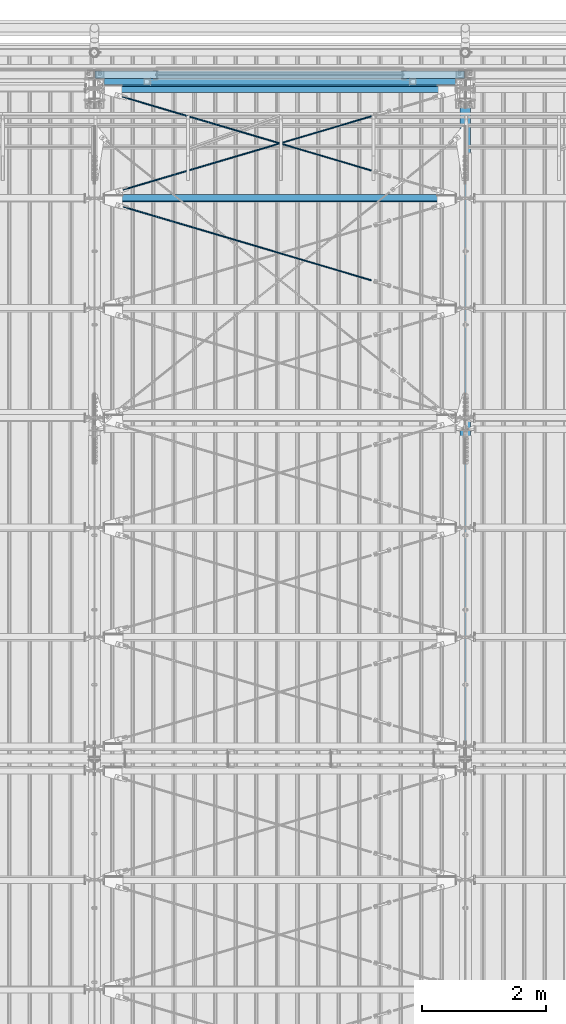
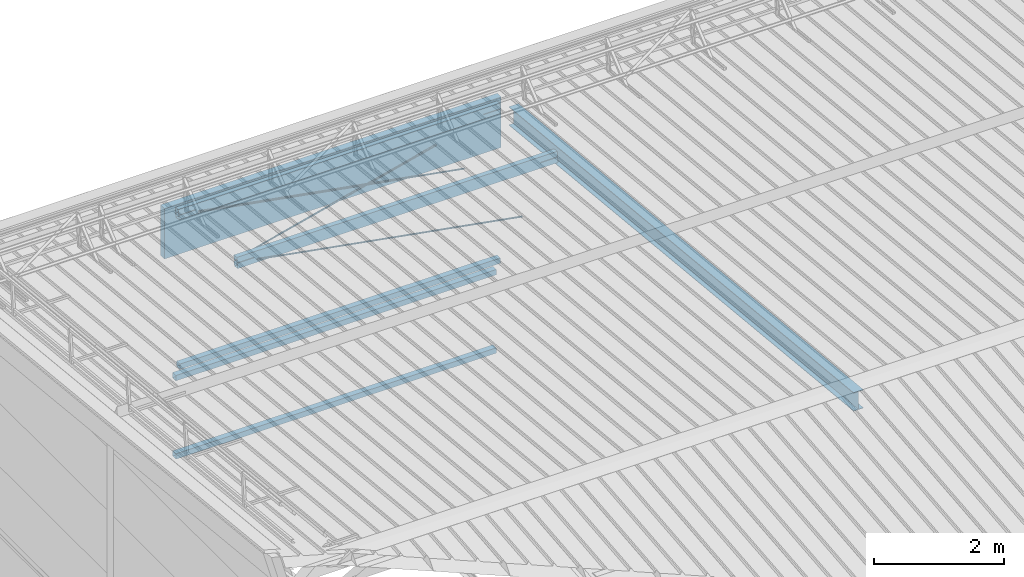
# One storey, part 265 of 709: 10 beams, 7 openings, 10 elements without a shape of their own.
"""IFC4 building model written with IfcOpenShell, lengths in millimetres."""

from ifc_helpers import new_model, si_unit, direction, frame, origin_with_axes, place, context, subcontext, project, spatial, line, indexed_curve, outline, extrude, polygons, material, element, aggregate, save


model = new_model("IFC4")

# Units and contexts
model_context = context("Model", 3, precision=0.2, world=origin_with_axes(), true_north=direction((0.0, 1.0)))
body_context = subcontext(model_context, "Body", "Model", "MODEL_VIEW")
reference_context = subcontext(model_context, "Reference", "Model", "MODEL_VIEW")
ifc_project = project(units=[si_unit("LENGTHUNIT", "METRE", prefix="MILLI"), si_unit("AREAUNIT", "SQUARE_METRE"), si_unit("VOLUMEUNIT", "CUBIC_METRE"), si_unit("MASSUNIT", "GRAM", prefix="KILO"), si_unit("TIMEUNIT", "SECOND"), si_unit("PLANEANGLEUNIT", "RADIAN"), si_unit("SOLIDANGLEUNIT", "STERADIAN"), si_unit("THERMODYNAMICTEMPERATUREUNIT", "DEGREE_CELSIUS"), si_unit("LUMINOUSINTENSITYUNIT", "LUMEN")], contexts=[model_context])

# Site, building, storey
site_placement = place(None, origin_with_axes())
site = spatial("IfcSite", under=ifc_project, at=site_placement, CompositionType="ELEMENT")
building_placement = place(site_placement, origin_with_axes())
building = spatial("IfcBuilding", under=site, at=building_placement, Name="Undefined", CompositionType="ELEMENT")
storey_placement = place(building_placement, origin_with_axes())
storey = spatial("IfcBuildingStorey", under=building, at=storey_placement, Name="Undefined", CompositionType="ELEMENT", Elevation=0.0)

# Assembly, beam
assembly_1_placement = place(storey_placement, frame((10000.0, 21654.0, 7089.70002), z_axis=(-1.0, 0.0, 0.0), x_axis=(0.0, -0.9950371902, 0.099503719)))
assembly_1 = element("IfcElementAssembly", 1, at=assembly_1_placement, inside=storey)
ifc_material_1 = material(Name="C355-5", Category="STEEL")
beam_1_placement = place(assembly_1_placement, origin_with_axes())
beam_1 = element("IfcBeam", 2, at=beam_1_placement, material=ifc_material_1, ObjectType="432", context=body_context, shape_type="Tessellation", body=[
    polygons([(3.80474, -173.0, -87.0), (4.70474, -164.0, -87.0), (10665.6128, -164.0, -87.0), (10664.7128, -173.0, -87.0), (4.70474, -164.0, -3.0), (10665.6128, -164.0, -3.0), (37.50474, 164.0, -3.0), (10698.4128, 164.0, -3.0), (37.50474, 164.0, -87.0), (10698.4128, 164.0, -87.0), (38.40474, 173.0, -87.0), (10699.3128, 173.0, -87.0), (38.40474, 173.0, 87.0), (10699.3128, 173.0, 87.0), (37.50474, 164.0, 87.0), (10698.4128, 164.0, 87.0), (37.50474, 164.0, 3.0), (10698.4128, 164.0, 3.0), (4.70474, -164.0, 3.0), (10665.6128, -164.0, 3.0), (4.70474, -164.0, 87.0), (10665.6128, -164.0, 87.0), (3.80474, -173.0, 87.0), (10664.7128, -173.0, 87.0)], [[[1, 2, 3, 4]], [[2, 5, 6, 3]], [[5, 7, 8, 6]], [[7, 9, 10, 8]], [[9, 11, 12, 10]], [[11, 13, 14, 12]], [[13, 15, 16, 14]], [[15, 17, 18, 16]], [[17, 19, 20, 18]], [[19, 21, 22, 20]], [[21, 23, 24, 22]], [[23, 1, 4, 24]], [[6, 8, 10, 12, 14, 16, 18, 20, 22, 24, 4, 3]], [[23, 21, 19, 17, 15, 13, 11, 9, 7, 5, 2, 1]]], closed=True),
])
aggregate(assembly_1, [beam_1])

assembly_2_placement = place(storey_placement, frame((10000.0, 21950.0, 2550.0), z_axis=(0.0, 0.0, -1.0), x_axis=(-1.0, 0.0, 0.0)))
assembly_2 = element("IfcElementAssembly", 3, at=assembly_2_placement, inside=storey)
ifc_material_2 = material(Name="C355", Category="STEEL")
beam_2_placement = place(assembly_2_placement, origin_with_axes())
beam_2 = element("IfcBeam", 4, at=beam_2_placement, material=ifc_material_2, ObjectType="545", context=body_context, shape_type="Tessellation", body=[
    polygons([(155.0, -47.0, -47.0), (155.0, -47.0, 47.0), (5845.0, -47.0, 47.0), (5845.0, -47.0, -47.0), (155.0, 47.0, 47.0), (5845.0, 47.0, 47.0), (155.0, 47.0, -47.0), (5845.0, 47.0, -47.0), (155.0, -50.0, -50.0), (155.0, 50.0, -50.0), (5845.0, 50.0, -50.0), (5845.0, -50.0, -50.0), (155.0, 50.0, 50.0), (5845.0, 50.0, 50.0), (155.0, -50.0, 50.0), (5845.0, -50.0, 50.0)], [[[1, 2, 3, 4]], [[2, 5, 6, 3]], [[5, 7, 8, 6]], [[7, 1, 4, 8]], [[9, 10, 11, 12]], [[10, 13, 14, 11]], [[13, 15, 16, 14]], [[15, 9, 12, 16]], [[14, 16, 12, 11], [6, 8, 4, 3]], [[15, 13, 10, 9], [7, 5, 2, 1]]], closed=True),
])
aggregate(assembly_2, [beam_2])

assembly_3_placement = place(storey_placement, frame((10000.0, 21950.0, 4020.0), z_axis=(0.0, 0.0, -1.0), x_axis=(-1.0, 0.0, 0.0)))
assembly_3 = element("IfcElementAssembly", 5, at=assembly_3_placement, inside=storey)
beam_3_placement = place(assembly_3_placement, origin_with_axes())
beam_3 = element("IfcBeam", 6, at=beam_3_placement, material=ifc_material_2, ObjectType="545", context=body_context, shape_type="Tessellation", body=[
    polygons([(155.0, -47.0, -47.0), (155.0, -47.0, 47.0), (5845.0, -47.0, 47.0), (5845.0, -47.0, -47.0), (155.0, 47.0, 47.0), (5845.0, 47.0, 47.0), (155.0, 47.0, -47.0), (5845.0, 47.0, -47.0), (155.0, -50.0, -50.0), (155.0, 50.0, -50.0), (5845.0, 50.0, -50.0), (5845.0, -50.0, -50.0), (155.0, 50.0, 50.0), (5845.0, 50.0, 50.0), (155.0, -50.0, 50.0), (5845.0, -50.0, 50.0)], [[[1, 2, 3, 4]], [[2, 5, 6, 3]], [[5, 7, 8, 6]], [[7, 1, 4, 8]], [[9, 10, 11, 12]], [[10, 13, 14, 11]], [[13, 15, 16, 14]], [[15, 9, 12, 16]], [[14, 16, 12, 11], [6, 8, 4, 3]], [[15, 13, 10, 9], [7, 5, 2, 1]]], closed=True),
])
aggregate(assembly_3, [beam_3])

assembly_4_placement = place(storey_placement, frame((10000.0, 21827.0, 4310.0), z_axis=(0.0, 0.0, -1.0), x_axis=(-1.0, 0.0, 0.0)))
assembly_4 = element("IfcElementAssembly", 7, at=assembly_4_placement, inside=storey)
beam_4_placement = place(assembly_4_placement, origin_with_axes())
beam_4 = element("IfcBeam", 8, at=beam_4_placement, material=ifc_material_2, ObjectType="546", context=body_context, shape_type="Tessellation", body=[
    polygons([(155.0, -47.0, -47.0), (155.0, -47.0, 47.0), (5845.0, -47.0, 47.0), (5845.0, -47.0, -47.0), (155.0, 47.0, 47.0), (5845.0, 47.0, 47.0), (155.0, 47.0, -47.0), (5845.0, 47.0, -47.0), (155.0, -50.0, -50.0), (155.0, 50.0, -50.0), (5845.0, 50.0, -50.0), (5845.0, -50.0, -50.0), (155.0, 50.0, 50.0), (5845.0, 50.0, 50.0), (155.0, -50.0, 50.0), (5845.0, -50.0, 50.0)], [[[1, 2, 3, 4]], [[2, 5, 6, 3]], [[5, 7, 8, 6]], [[7, 1, 4, 8]], [[9, 10, 11, 12]], [[10, 13, 14, 11]], [[13, 15, 16, 14]], [[15, 9, 12, 16]], [[14, 16, 12, 11], [6, 8, 4, 3]], [[15, 13, 10, 9], [7, 5, 2, 1]]], closed=True),
])
aggregate(assembly_4, [beam_4])

# Assembly, beam, voiding feature
assembly_5_placement = place(storey_placement, frame((4000.0, 20064.14591, 7330.08943), z_axis=(-0.2852311229, -0.9537021177, 0.0953702118), x_axis=(0.9584587662, -0.2838155751, 0.028381558)))
assembly_5 = element("IfcElementAssembly", 9, at=assembly_5_placement, inside=storey)
beam_5_placement = place(assembly_5_placement, origin_with_axes())
beam_5 = element("IfcBeam", 10, at=beam_5_placement, material=ifc_material_1, ObjectType="570", context=body_context, shape_type="Tessellation", body=[
    polygons([(4850.05021, 7.36122, 4.25), (4850.05021, 6.01041, 6.01041), (4850.05021, 4.25, 7.36121), (4850.05021, 2.19996, 8.21037), (4850.05021, 0.0, 8.5), (4850.05021, -2.19996, 8.21037), (4850.05021, -4.25, 7.36121), (4850.05021, -6.01041, 6.01041), (4850.05021, -7.36121, 4.25), (4850.05021, -8.21037, 2.19996), (4850.05021, -8.5, 0.0), (4850.05021, -8.21037, -2.19996), (4850.05021, -7.36121, -4.25), (4850.05021, -6.01041, -6.01041), (4850.05021, -4.25, -7.36122), (4850.05021, -2.19996, -8.21037), (4850.05021, 0.0, -8.5), (4850.05021, 2.19996, -8.21037), (4850.05021, 4.25, -7.36122), (4850.05021, 6.01041, -6.01041), (4850.05021, 7.36122, -4.25), (4850.05021, 8.21037, -2.19996), (4850.05021, 8.5, 0.0), (4850.05021, 8.21037, 2.19996), (4670.05021, 8.21037, 2.19996), (4670.05021, 7.36122, 4.25), (4670.05021, 6.01041, 6.01041), (4670.05021, 4.25, 7.36121), (4670.05021, 2.19996, 8.21037), (4670.05021, 0.0, 8.5), (4670.05021, -2.19996, 8.21037), (4670.05021, -4.25, 7.36121), (4670.05021, -6.01041, 6.01041), (4670.05021, -7.36121, 4.25), (4670.05021, -8.21037, 2.19996), (4670.05021, -8.5, 0.0), (4670.05021, -8.21037, -2.19996), (4670.05021, -7.36121, -4.25), (4670.05021, -6.01041, -6.01041), (4670.05021, -4.25, -7.36122), (4670.05021, -2.19996, -8.21037), (4670.05021, 0.0, -8.5), (4670.05021, 2.19996, -8.21037), (4670.05021, 4.25, -7.36122), (4670.05021, 6.01041, -6.01041), (4670.05021, 7.36122, -4.25), (4670.05021, 8.21037, -2.19996), (4670.05021, 8.5, 0.0), (4670.05021, 10.0, 0.0), (4670.05021, 9.65926, 2.58819), (4670.05021, 8.66025, 5.0), (4670.05021, 7.07107, 7.07107), (4670.05021, 5.0, 8.66025), (4670.05021, 2.58819, 9.65926), (4670.05021, 0.0, 10.0), (4670.05021, -2.58819, 9.65926), (4670.05021, -5.0, 8.66025), (4670.05021, -7.07107, 7.07107), (4670.05021, -8.66025, 5.0), (4670.05021, -9.65926, 2.58819), (4670.05021, -10.0, 0.0), (4670.05021, -9.65926, -2.58819), (4670.05021, -8.66025, -5.0), (4670.05021, -7.07107, -7.07107), (4670.05021, -5.0, -8.66025), (4670.05021, -2.58819, -9.65926), (4670.05021, 0.0, -10.0), (4670.05021, 2.58819, -9.65926), (4670.05021, 5.0, -8.66025), (4670.05021, 7.07107, -7.07107), (4670.05021, 8.66025, -5.0), (4670.05021, 9.65926, -2.58819), (483.0251, 2.58819, 9.65926), (483.0251, 5.0, 8.66025), (483.0251, 7.07107, 7.07107), (483.0251, 8.66025, 5.0), (483.0251, 9.65926, 2.58819), (483.0251, 10.0, 0.0), (483.0251, 9.65926, -2.58819), (483.0251, 8.66025, -5.0), (483.0251, 7.07107, -7.07107), (483.0251, 5.0, -8.66025), (483.0251, 2.58819, -9.65926), (483.0251, 0.0, -10.0), (483.0251, -2.58819, -9.65926), (483.0251, -5.0, -8.66025), (483.0251, -7.07107, -7.07107), (483.0251, -8.66025, -5.0), (483.0251, -9.65926, -2.58819), (483.0251, -10.0, 0.0), (483.0251, -9.65926, 2.58819), (483.0251, -8.66025, 5.0), (483.0251, -7.07107, 7.07107), (483.0251, -5.0, 8.66025), (483.0251, -2.58819, 9.65926), (483.0251, 0.0, 10.0)], [[[1, 2, 3, 4, 5, 6, 7, 8, 9, 10, 11, 12, 13, 14, 15, 16, 17, 18, 19, 20, 21, 22, 23, 24]], [[24, 25, 26, 1]], [[1, 26, 27, 2]], [[2, 27, 28, 3]], [[3, 28, 29, 4]], [[4, 29, 30, 5]], [[5, 30, 31, 6]], [[6, 31, 32, 7]], [[7, 32, 33, 8]], [[8, 33, 34, 9]], [[9, 34, 35, 10]], [[10, 35, 36, 11]], [[11, 36, 37, 12]], [[12, 37, 38, 13]], [[13, 38, 39, 14]], [[14, 39, 40, 15]], [[15, 40, 41, 16]], [[16, 41, 42, 17]], [[17, 42, 43, 18]], [[18, 43, 44, 19]], [[19, 44, 45, 20]], [[20, 45, 46, 21]], [[21, 46, 47, 22]], [[22, 47, 48, 23]], [[23, 48, 25, 24]], [[49, 50, 51, 52, 53, 54, 55, 56, 57, 58, 59, 60, 61, 62, 63, 64, 65, 66, 67, 68, 69, 70, 71, 72], [47, 46, 45, 44, 43, 42, 41, 40, 39, 38, 37, 36, 35, 34, 33, 32, 31, 30, 29, 28, 27, 26, 25, 48]], [[73, 74, 75, 76, 77, 78, 79, 80, 81, 82, 83, 84, 85, 86, 87, 88, 89, 90, 91, 92, 93, 94, 95, 96]], [[79, 78, 49, 72]], [[80, 79, 72, 71]], [[81, 80, 71, 70]], [[82, 81, 70, 69]], [[83, 82, 69, 68]], [[84, 83, 68, 67]], [[85, 84, 67, 66]], [[86, 85, 66, 65]], [[87, 86, 65, 64]], [[88, 87, 64, 63]], [[89, 88, 63, 62]], [[90, 89, 62, 61]], [[91, 90, 61, 60]], [[92, 91, 60, 59]], [[93, 92, 59, 58]], [[94, 93, 58, 57]], [[95, 94, 57, 56]], [[96, 95, 56, 55]], [[73, 96, 55, 54]], [[74, 73, 54, 53]], [[75, 74, 53, 52]], [[76, 75, 52, 51]], [[77, 76, 51, 50]], [[78, 77, 50, 49]]], closed=True),
])
voiding_feature_1_placement = place(beam_5_placement, frame((4850.05021, 0.0, 0.0), z_axis=(0.0, 1.0, 0.0), x_axis=(-1.0, 0.0, 0.0)))
element("IfcVoidingFeature", 11, at=voiding_feature_1_placement, cuts=beam_5, PredefinedType="HOLE", context=reference_context, identifier="Reference", shape_type="SolidModel", body=[
    extrude(outline(indexed_curve([(10.5, 0.0), (10.14222, 2.7176), (9.09327, 5.25), (7.42462, 7.42462), (5.25, 9.09327), (2.7176, 10.14222), (0.0, 10.5), (-2.7176, 10.14222), (-5.25, 9.09327), (-7.42462, 7.42462), (-9.09327, 5.25), (-10.14222, 2.7176), (-10.5, 0.0), (-10.14222, -2.7176), (-9.09327, -5.25), (-7.42462, -7.42462), (-5.25, -9.09327), (-2.7176, -10.14222), (0.0, -10.5), (2.7176, -10.14222), (5.25, -9.09327), (7.42462, -7.42462), (9.09327, -5.25), (10.14222, -2.7176)], segments=[line(1, 2, 3, 4, 5, 6, 7, 8, 9, 10, 11, 12, 13, 14, 15, 16, 17, 18, 19, 20, 21, 22, 23, 24, 1)])), frame((0.0, 0.0, 0.0), z_axis=(-1.0, 0.0, 0.0), x_axis=(0.0, 0.0, 1.0)), (0.0, 0.0, -1.0), 180.0),
])
aggregate(assembly_5, [beam_5])

assembly_6_placement = place(storey_placement, frame((4000.0, 20064.14591, 7330.08943), z_axis=(0.2852311229, -0.9537021177, 0.0953702118), x_axis=(0.9584587662, 0.2838155751, -0.028381558)))
assembly_6 = element("IfcElementAssembly", 12, at=assembly_6_placement, inside=storey)
beam_6_placement = place(assembly_6_placement, origin_with_axes())
beam_6 = element("IfcBeam", 13, at=beam_6_placement, material=ifc_material_1, ObjectType="570", context=body_context, shape_type="Tessellation", body=[
    polygons([(4850.05021, 7.36122, 4.25), (4850.05021, 6.01041, 6.01041), (4850.05021, 4.25, 7.36121), (4850.05021, 2.19996, 8.21037), (4850.05021, 0.0, 8.5), (4850.05021, -2.19996, 8.21037), (4850.05021, -4.25, 7.36121), (4850.05021, -6.01041, 6.01041), (4850.05021, -7.36121, 4.25), (4850.05021, -8.21037, 2.19996), (4850.05021, -8.5, 0.0), (4850.05021, -8.21037, -2.19996), (4850.05021, -7.36121, -4.25), (4850.05021, -6.01041, -6.01041), (4850.05021, -4.25, -7.36122), (4850.05021, -2.19996, -8.21037), (4850.05021, 0.0, -8.5), (4850.05021, 2.19996, -8.21037), (4850.05021, 4.25, -7.36122), (4850.05021, 6.01041, -6.01041), (4850.05021, 7.36122, -4.25), (4850.05021, 8.21037, -2.19996), (4850.05021, 8.5, 0.0), (4850.05021, 8.21037, 2.19996), (4670.05021, 8.21037, 2.19996), (4670.05021, 7.36122, 4.25), (4670.05021, 6.01041, 6.01041), (4670.05021, 4.25, 7.36121), (4670.05021, 2.19996, 8.21037), (4670.05021, 0.0, 8.5), (4670.05021, -2.19996, 8.21037), (4670.05021, -4.25, 7.36121), (4670.05021, -6.01041, 6.01041), (4670.05021, -7.36121, 4.25), (4670.05021, -8.21037, 2.19996), (4670.05021, -8.5, 0.0), (4670.05021, -8.21037, -2.19996), (4670.05021, -7.36121, -4.25), (4670.05021, -6.01041, -6.01041), (4670.05021, -4.25, -7.36122), (4670.05021, -2.19996, -8.21037), (4670.05021, 0.0, -8.5), (4670.05021, 2.19996, -8.21037), (4670.05021, 4.25, -7.36122), (4670.05021, 6.01041, -6.01041), (4670.05021, 7.36122, -4.25), (4670.05021, 8.21037, -2.19996), (4670.05021, 8.5, 0.0), (4670.05021, 10.0, 0.0), (4670.05021, 9.65926, 2.58819), (4670.05021, 8.66025, 5.0), (4670.05021, 7.07107, 7.07107), (4670.05021, 5.0, 8.66025), (4670.05021, 2.58819, 9.65926), (4670.05021, 0.0, 10.0), (4670.05021, -2.58819, 9.65926), (4670.05021, -5.0, 8.66025), (4670.05021, -7.07107, 7.07107), (4670.05021, -8.66025, 5.0), (4670.05021, -9.65926, 2.58819), (4670.05021, -10.0, 0.0), (4670.05021, -9.65926, -2.58819), (4670.05021, -8.66025, -5.0), (4670.05021, -7.07107, -7.07107), (4670.05021, -5.0, -8.66025), (4670.05021, -2.58819, -9.65926), (4670.05021, 0.0, -10.0), (4670.05021, 2.58819, -9.65926), (4670.05021, 5.0, -8.66025), (4670.05021, 7.07107, -7.07107), (4670.05021, 8.66025, -5.0), (4670.05021, 9.65926, -2.58819), (483.0251, 2.58819, 9.65926), (483.0251, 5.0, 8.66025), (483.0251, 7.07107, 7.07107), (483.0251, 8.66025, 5.0), (483.0251, 9.65926, 2.58819), (483.0251, 10.0, 0.0), (483.0251, 9.65926, -2.58819), (483.0251, 8.66025, -5.0), (483.0251, 7.07107, -7.07107), (483.0251, 5.0, -8.66025), (483.0251, 2.58819, -9.65926), (483.0251, 0.0, -10.0), (483.0251, -2.58819, -9.65926), (483.0251, -5.0, -8.66025), (483.0251, -7.07107, -7.07107), (483.0251, -8.66025, -5.0), (483.0251, -9.65926, -2.58819), (483.0251, -10.0, 0.0), (483.0251, -9.65926, 2.58819), (483.0251, -8.66025, 5.0), (483.0251, -7.07107, 7.07107), (483.0251, -5.0, 8.66025), (483.0251, -2.58819, 9.65926), (483.0251, 0.0, 10.0)], [[[1, 2, 3, 4, 5, 6, 7, 8, 9, 10, 11, 12, 13, 14, 15, 16, 17, 18, 19, 20, 21, 22, 23, 24]], [[24, 25, 26, 1]], [[1, 26, 27, 2]], [[2, 27, 28, 3]], [[3, 28, 29, 4]], [[4, 29, 30, 5]], [[5, 30, 31, 6]], [[6, 31, 32, 7]], [[7, 32, 33, 8]], [[8, 33, 34, 9]], [[9, 34, 35, 10]], [[10, 35, 36, 11]], [[11, 36, 37, 12]], [[12, 37, 38, 13]], [[13, 38, 39, 14]], [[14, 39, 40, 15]], [[15, 40, 41, 16]], [[16, 41, 42, 17]], [[17, 42, 43, 18]], [[18, 43, 44, 19]], [[19, 44, 45, 20]], [[20, 45, 46, 21]], [[21, 46, 47, 22]], [[22, 47, 48, 23]], [[23, 48, 25, 24]], [[49, 50, 51, 52, 53, 54, 55, 56, 57, 58, 59, 60, 61, 62, 63, 64, 65, 66, 67, 68, 69, 70, 71, 72], [47, 46, 45, 44, 43, 42, 41, 40, 39, 38, 37, 36, 35, 34, 33, 32, 31, 30, 29, 28, 27, 26, 25, 48]], [[73, 74, 75, 76, 77, 78, 79, 80, 81, 82, 83, 84, 85, 86, 87, 88, 89, 90, 91, 92, 93, 94, 95, 96]], [[79, 78, 49, 72]], [[80, 79, 72, 71]], [[81, 80, 71, 70]], [[82, 81, 70, 69]], [[83, 82, 69, 68]], [[84, 83, 68, 67]], [[85, 84, 67, 66]], [[86, 85, 66, 65]], [[87, 86, 65, 64]], [[88, 87, 64, 63]], [[89, 88, 63, 62]], [[90, 89, 62, 61]], [[91, 90, 61, 60]], [[92, 91, 60, 59]], [[93, 92, 59, 58]], [[94, 93, 58, 57]], [[95, 94, 57, 56]], [[96, 95, 56, 55]], [[73, 96, 55, 54]], [[74, 73, 54, 53]], [[75, 74, 53, 52]], [[76, 75, 52, 51]], [[77, 76, 51, 50]], [[78, 77, 50, 49]]], closed=True),
])
voiding_feature_2_placement = place(beam_6_placement, frame((4850.05021, 0.0, 0.0), z_axis=(0.0, 1.0, 0.0), x_axis=(-1.0, 0.0, 0.0)))
element("IfcVoidingFeature", 14, at=voiding_feature_2_placement, cuts=beam_6, PredefinedType="HOLE", context=reference_context, identifier="Reference", shape_type="SolidModel", body=[
    extrude(outline(indexed_curve([(10.5, 0.0), (10.14222, 2.7176), (9.09327, 5.25), (7.42462, 7.42462), (5.25, 9.09327), (2.7176, 10.14222), (0.0, 10.5), (-2.7176, 10.14222), (-5.25, 9.09327), (-7.42462, 7.42462), (-9.09327, 5.25), (-10.14222, 2.7176), (-10.5, 0.0), (-10.14222, -2.7176), (-9.09327, -5.25), (-7.42462, -7.42462), (-5.25, -9.09327), (-2.7176, -10.14222), (0.0, -10.5), (2.7176, -10.14222), (5.25, -9.09327), (7.42462, -7.42462), (9.09327, -5.25), (10.14222, -2.7176)], segments=[line(1, 2, 3, 4, 5, 6, 7, 8, 9, 10, 11, 12, 13, 14, 15, 16, 17, 18, 19, 20, 21, 22, 23, 24, 1)])), frame((0.0, 0.0, 0.0), z_axis=(-1.0, 0.0, 0.0), x_axis=(0.0, 0.0, 1.0)), (0.0, 0.0, -1.0), 180.0),
])
aggregate(assembly_6, [beam_6])

assembly_7_placement = place(storey_placement, frame((4000.0, 21840.84566, 7152.41945), z_axis=(-0.2852311229, -0.9537021177, 0.0953702118), x_axis=(0.9584587662, -0.2838155751, 0.028381558)))
assembly_7 = element("IfcElementAssembly", 15, at=assembly_7_placement, inside=storey)
beam_7_placement = place(assembly_7_placement, origin_with_axes())
beam_7 = element("IfcBeam", 16, at=beam_7_placement, material=ifc_material_1, ObjectType="568", context=body_context, shape_type="Tessellation", body=[
    polygons([(4850.05021, 7.36121, 4.25), (4850.05021, 6.01041, 6.01041), (4850.05021, 4.25, 7.36122), (4850.05021, 2.19996, 8.21037), (4850.05021, 0.0, 8.5), (4850.05021, -2.19996, 8.21037), (4850.05021, -4.25, 7.36122), (4850.05021, -6.01041, 6.01041), (4850.05021, -7.36122, 4.25), (4850.05021, -8.21037, 2.19996), (4850.05021, -8.5, 0.0), (4850.05021, -8.21037, -2.19996), (4850.05021, -7.36122, -4.25), (4850.05021, -6.01041, -6.01041), (4850.05021, -4.25, -7.36121), (4850.05021, -2.19996, -8.21037), (4850.05021, 0.0, -8.5), (4850.05021, 2.19996, -8.21037), (4850.05021, 4.25, -7.36121), (4850.05021, 6.01041, -6.01041), (4850.05021, 7.36121, -4.25), (4850.05021, 8.21037, -2.19996), (4850.05021, 8.5, 0.0), (4850.05021, 8.21037, 2.19996), (4670.05021, 8.21037, 2.19996), (4670.05021, 7.36121, 4.25), (4670.05021, 6.01041, 6.01041), (4670.05021, 4.25, 7.36122), (4670.05021, 2.19996, 8.21037), (4670.05021, 0.0, 8.5), (4670.05021, -2.19996, 8.21037), (4670.05021, -4.25, 7.36122), (4670.05021, -6.01041, 6.01041), (4670.05021, -7.36122, 4.25), (4670.05021, -8.21037, 2.19996), (4670.05021, -8.5, 0.0), (4670.05021, -8.21037, -2.19996), (4670.05021, -7.36122, -4.25), (4670.05021, -6.01041, -6.01041), (4670.05021, -4.25, -7.36121), (4670.05021, -2.19996, -8.21037), (4670.05021, 0.0, -8.5), (4670.05021, 2.19996, -8.21037), (4670.05021, 4.25, -7.36121), (4670.05021, 6.01041, -6.01041), (4670.05021, 7.36121, -4.25), (4670.05021, 8.21037, -2.19996), (4670.05021, 8.5, 0.0), (4670.05021, 10.0, 0.0), (4670.05021, 9.65926, 2.58819), (4670.05021, 8.66025, 5.0), (4670.05021, 7.07107, 7.07107), (4670.05021, 5.0, 8.66025), (4670.05021, 2.58819, 9.65926), (4670.05021, 0.0, 10.0), (4670.05021, -2.58819, 9.65926), (4670.05021, -5.0, 8.66025), (4670.05021, -7.07107, 7.07107), (4670.05021, -8.66025, 5.0), (4670.05021, -9.65926, 2.58819), (4670.05021, -10.0, 0.0), (4670.05021, -9.65926, -2.58819), (4670.05021, -8.66025, -5.0), (4670.05021, -7.07107, -7.07107), (4670.05021, -5.0, -8.66025), (4670.05021, -2.58819, -9.65926), (4670.05021, 0.0, -10.0), (4670.05021, 2.58819, -9.65926), (4670.05021, 5.0, -8.66025), (4670.05021, 7.07107, -7.07107), (4670.05021, 8.66025, -5.0), (4670.05021, 9.65926, -2.58819), (468.0251, 2.58819, 9.65926), (468.0251, 5.0, 8.66025), (468.0251, 7.07107, 7.07107), (468.0251, 8.66025, 5.0), (468.0251, 9.65926, 2.58819), (468.0251, 10.0, 0.0), (468.0251, 9.65926, -2.58819), (468.0251, 8.66025, -5.0), (468.0251, 7.07107, -7.07107), (468.0251, 5.0, -8.66025), (468.0251, 2.58819, -9.65926), (468.0251, 0.0, -10.0), (468.0251, -2.58819, -9.65926), (468.0251, -5.0, -8.66025), (468.0251, -7.07107, -7.07107), (468.0251, -8.66025, -5.0), (468.0251, -9.65926, -2.58819), (468.0251, -10.0, 0.0), (468.0251, -9.65926, 2.58819), (468.0251, -8.66025, 5.0), (468.0251, -7.07107, 7.07107), (468.0251, -5.0, 8.66025), (468.0251, -2.58819, 9.65926), (468.0251, 0.0, 10.0)], [[[1, 2, 3, 4, 5, 6, 7, 8, 9, 10, 11, 12, 13, 14, 15, 16, 17, 18, 19, 20, 21, 22, 23, 24]], [[24, 25, 26, 1]], [[1, 26, 27, 2]], [[2, 27, 28, 3]], [[3, 28, 29, 4]], [[4, 29, 30, 5]], [[5, 30, 31, 6]], [[6, 31, 32, 7]], [[7, 32, 33, 8]], [[8, 33, 34, 9]], [[9, 34, 35, 10]], [[10, 35, 36, 11]], [[11, 36, 37, 12]], [[12, 37, 38, 13]], [[13, 38, 39, 14]], [[14, 39, 40, 15]], [[15, 40, 41, 16]], [[16, 41, 42, 17]], [[17, 42, 43, 18]], [[18, 43, 44, 19]], [[19, 44, 45, 20]], [[20, 45, 46, 21]], [[21, 46, 47, 22]], [[22, 47, 48, 23]], [[23, 48, 25, 24]], [[49, 50, 51, 52, 53, 54, 55, 56, 57, 58, 59, 60, 61, 62, 63, 64, 65, 66, 67, 68, 69, 70, 71, 72], [47, 46, 45, 44, 43, 42, 41, 40, 39, 38, 37, 36, 35, 34, 33, 32, 31, 30, 29, 28, 27, 26, 25, 48]], [[73, 74, 75, 76, 77, 78, 79, 80, 81, 82, 83, 84, 85, 86, 87, 88, 89, 90, 91, 92, 93, 94, 95, 96]], [[79, 78, 49, 72]], [[80, 79, 72, 71]], [[81, 80, 71, 70]], [[82, 81, 70, 69]], [[83, 82, 69, 68]], [[84, 83, 68, 67]], [[85, 84, 67, 66]], [[86, 85, 66, 65]], [[87, 86, 65, 64]], [[88, 87, 64, 63]], [[89, 88, 63, 62]], [[90, 89, 62, 61]], [[91, 90, 61, 60]], [[92, 91, 60, 59]], [[93, 92, 59, 58]], [[94, 93, 58, 57]], [[95, 94, 57, 56]], [[96, 95, 56, 55]], [[73, 96, 55, 54]], [[74, 73, 54, 53]], [[75, 74, 53, 52]], [[76, 75, 52, 51]], [[77, 76, 51, 50]], [[78, 77, 50, 49]]], closed=True),
])
voiding_feature_3_placement = place(beam_7_placement, frame((4850.05021, 0.0, 0.0), z_axis=(0.0, 1.0, 0.0), x_axis=(-1.0, 0.0, 0.0)))
element("IfcVoidingFeature", 17, at=voiding_feature_3_placement, cuts=beam_7, PredefinedType="HOLE", context=reference_context, identifier="Reference", shape_type="SolidModel", body=[
    extrude(outline(indexed_curve([(10.5, 0.0), (10.14222, 2.7176), (9.09327, 5.25), (7.42462, 7.42462), (5.25, 9.09327), (2.7176, 10.14222), (0.0, 10.5), (-2.7176, 10.14222), (-5.25, 9.09327), (-7.42462, 7.42462), (-9.09327, 5.25), (-10.14222, 2.7176), (-10.5, 0.0), (-10.14222, -2.7176), (-9.09327, -5.25), (-7.42462, -7.42462), (-5.25, -9.09327), (-2.7176, -10.14222), (0.0, -10.5), (2.7176, -10.14222), (5.25, -9.09327), (7.42462, -7.42462), (9.09327, -5.25), (10.14222, -2.7176)], segments=[line(1, 2, 3, 4, 5, 6, 7, 8, 9, 10, 11, 12, 13, 14, 15, 16, 17, 18, 19, 20, 21, 22, 23, 24, 1)])), frame((0.0, 0.0, 0.0), z_axis=(-1.0, 0.0, 0.0), x_axis=(0.0, 0.0, 1.0)), (0.0, 0.0, -1.0), 180.0),
])
aggregate(assembly_7, [beam_7])

# Assembly, beam, voiding features
assembly_8_placement = place(storey_placement, frame((10000.0, 20063.34988, 7322.12913), z_axis=(0.0, -0.9950371902, 0.099503719), x_axis=(-1.0, 0.0, 0.0)))
assembly_8 = element("IfcElementAssembly", 18, at=assembly_8_placement, inside=storey)
beam_8_placement = place(assembly_8_placement, origin_with_axes())
beam_8 = element("IfcBeam", 19, at=beam_8_placement, material=ifc_material_2, ObjectType="566", context=body_context, shape_type="Tessellation", body=[
    polygons([(456.62586, -5.0, 50.0), (456.62586, -5.0, 46.0), (155.0, -5.0, 46.0), (155.0, -5.0, 50.0), (456.62586, 5.0, 50.0), (456.62586, 5.0, 46.0), (155.0, 5.0, 50.0), (155.0, 5.0, 46.0), (456.62586, -5.0, -46.0), (456.62586, -5.0, -50.0), (155.0, -5.0, -50.0), (155.0, -5.0, -46.0), (456.62586, 5.0, -46.0), (456.62586, 5.0, -50.0), (155.0, 5.0, -46.0), (155.0, 5.0, -50.0), (155.0, 96.0, 46.0), (155.0, 96.0, -46.0), (5845.0, 96.0, -46.0), (5845.0, 96.0, 46.0), (155.0, 100.0, -50.0), (5845.0, 100.0, -50.0), (5845.0, 5.0, -50.0), (5543.37413, 5.0, -50.0), (5543.37413, -5.0, -50.0), (5845.0, -5.0, -50.0), (5845.0, -100.0, -50.0), (155.0, -100.0, -50.0), (5845.00055, 5.0, -46.0), (5543.37413, 5.0, -46.0), (5543.37413, -5.0, -46.0), (5845.0, -5.0, -46.0), (155.0, -96.0, -46.0), (155.0, -96.0, 46.0), (5845.0, -96.0, 46.0), (5845.0, -96.0, -46.0), (5543.37413, -5.0, 50.0), (5543.37413, -5.0, 46.0), (5543.37413, 5.0, 46.0), (5543.37413, 5.0, 50.0), (5845.0, -5.0, 50.0), (5845.0, -5.0, 46.0), (5845.0, -100.0, 50.0), (155.0, -100.0, 50.0), (5845.0, 5.0, 46.0), (5845.00055, 5.0, 50.0), (5845.0, 100.0, 50.0), (155.0, 100.0, 50.0)], [[[1, 2, 3, 4]], [[5, 6, 2, 1]], [[7, 8, 6, 5]], [[9, 10, 11, 12]], [[13, 14, 10, 9]], [[15, 16, 14, 13]], [[17, 18, 19, 20]], [[21, 22, 23, 24, 25, 26, 27, 28, 11, 10, 14, 16]], [[29, 30, 24, 23]], [[31, 25, 24, 30]], [[32, 26, 25, 31]], [[33, 34, 35, 36]], [[37, 38, 39, 40]], [[41, 42, 38, 37]], [[43, 27, 26, 32, 36, 35, 42, 41]], [[44, 28, 27, 43]], [[34, 33, 12, 11, 28, 44, 4, 3]], [[17, 20, 45, 39, 38, 42, 35, 34, 3, 2, 6, 8]], [[46, 40, 39, 45]], [[20, 19, 29, 23, 22, 47, 46, 45]], [[21, 48, 47, 22]], [[4, 44, 43, 41, 37, 40, 46, 47, 48, 7, 5, 1]], [[48, 21, 16, 15, 18, 17, 8, 7]], [[12, 33, 36, 32, 31, 30, 29, 19, 18, 15, 13, 9]]], closed=True),
])
voiding_feature_4_placement = place(beam_8_placement, frame((5845.00055, 0.0, -93.07721), z_axis=(0.0, -1.0, 0.0), x_axis=(0.0, 0.0, 1.0)))
element("IfcVoidingFeature", 20, at=voiding_feature_4_placement, cuts=beam_8, Name="PLATE", PredefinedType="HOLE", context=reference_context, identifier="Reference", shape_type="SolidModel", body=[
    extrude(outline(indexed_curve([(0.0, 0.0), (186.15442, 0.0), (268.27702, 275.95562), (182.01573, 301.62642), (4.13868, 301.62642), (-82.1226, 275.95562)], segments=[line(1, 2, 3, 4, 5, 6, 1)])), frame((0.0, 0.0, 5.0), z_axis=(0.0, 0.0, 1.0), x_axis=(1.0, 0.0, 0.0)), (0.0, 0.0, -1.0), 10.0),
])
voiding_feature_5_placement = place(beam_8_placement, frame((154.99945, 0.0, 93.07721), z_axis=(0.0, -1.0, 0.0), x_axis=(0.0, 0.0, -1.0)))
element("IfcVoidingFeature", 21, at=voiding_feature_5_placement, cuts=beam_8, Name="PLATE", PredefinedType="HOLE", context=reference_context, identifier="Reference", shape_type="SolidModel", body=[
    extrude(outline(indexed_curve([(0.0, 0.0), (186.15442, 0.0), (268.27702, 275.95562), (182.01573, 301.62642), (4.13868, 301.62642), (-82.1226, 275.95562)], segments=[line(1, 2, 3, 4, 5, 6, 1)])), frame((0.0, 0.0, 5.0), z_axis=(0.0, 0.0, 1.0), x_axis=(1.0, 0.0, 0.0)), (0.0, 0.0, -1.0), 10.0),
])
aggregate(assembly_8, [beam_8])

assembly_9_placement = place(storey_placement, frame((10000.0, 21841.04467, 7154.40952), z_axis=(0.0, -0.9950371902, 0.099503719), x_axis=(-1.0, 0.0, 0.0)))
assembly_9 = element("IfcElementAssembly", 22, at=assembly_9_placement, inside=storey)
beam_9_placement = place(assembly_9_placement, origin_with_axes())
beam_9 = element("IfcBeam", 23, at=beam_9_placement, material=ifc_material_2, ObjectType="565", context=body_context, shape_type="Tessellation", body=[
    polygons([(5855.0, 5.0, 50.0), (5855.0, 5.0, 46.0), (5557.75102, 5.0, 46.0), (5557.75102, 5.0, 50.0), (5557.75102, 15.0, 46.0), (5557.75102, 15.0, 50.0), (5855.0, 15.0, 50.0), (5855.0, 15.0, 46.0), (5855.0, 5.0, -46.0), (5855.0, 5.0, -50.0), (5557.75102, 5.0, -50.0), (5557.75102, 5.0, -46.0), (5557.75102, 15.0, -50.0), (5557.75102, 15.0, -46.0), (5855.0, 15.0, -46.0), (5855.0, 15.0, -50.0), (145.0, 86.0, 46.0), (145.0, 86.0, -46.0), (5855.0, 86.0, -46.0), (5855.0, 86.0, 46.0), (5855.0, -86.0, 46.0), (145.0, -86.0, 46.0), (145.0, 5.0, 46.0), (442.24898, 5.0, 46.0), (442.24898, 15.0, 46.0), (145.0, 15.0, 46.0), (145.0, -86.0, -46.0), (5855.0, -86.0, -46.0), (145.0, 15.0, -46.0), (145.0, 15.0, -50.0), (442.24898, 15.0, -50.0), (442.24898, 15.0, -46.0), (442.24898, 5.0, -50.0), (442.24898, 5.0, -46.0), (145.0, 5.0, -50.0), (145.0, 5.0, -46.0), (145.0, -90.0, -50.0), (145.0, -90.0, 50.0), (145.0, 5.0, 50.0), (442.24898, 5.0, 50.0), (442.24898, 15.0, 50.0), (145.0, 15.0, 50.0), (145.0, 90.0, 50.0), (145.0, 90.0, -50.0), (5855.0, 90.0, 50.0), (5855.0, 90.0, -50.0), (5855.0, -90.0, -50.0), (5855.0, -90.0, 50.0)], [[[1, 2, 3, 4]], [[4, 3, 5, 6]], [[7, 6, 5, 8]], [[9, 10, 11, 12]], [[12, 11, 13, 14]], [[15, 14, 13, 16]], [[17, 18, 19, 20]], [[3, 2, 21, 22, 23, 24, 25, 26, 17, 20, 8, 5]], [[27, 22, 21, 28]], [[29, 30, 31, 32]], [[32, 31, 33, 34]], [[34, 33, 35, 36]], [[22, 27, 36, 35, 37, 38, 39, 23]], [[40, 24, 23, 39]], [[41, 25, 24, 40]], [[42, 26, 25, 41]], [[43, 44, 30, 29, 18, 17, 26, 42]], [[44, 43, 45, 46]], [[20, 19, 15, 16, 46, 45, 7, 8]], [[11, 10, 47, 37, 35, 33, 31, 30, 44, 46, 16, 13]], [[38, 37, 47, 48]], [[45, 43, 42, 41, 40, 39, 38, 48, 1, 4, 6, 7]], [[48, 47, 10, 9, 28, 21, 2, 1]], [[19, 18, 29, 32, 34, 36, 27, 28, 9, 12, 14, 15]]], closed=True),
])
voiding_feature_6_placement = place(beam_9_placement, frame((145.0, 10.0, -70.0), z_axis=(0.0, -1.0, 0.0), x_axis=(1.0, 0.0, 0.0)))
element("IfcVoidingFeature", 24, at=voiding_feature_6_placement, cuts=beam_9, PredefinedType="HOLE", context=reference_context, identifier="Reference", shape_type="SolidModel", body=[
    extrude(outline(indexed_curve([(0.0, 0.0), (297.24898, 0.0), (297.24898, 154.66006), (271.57818, 240.92135), (0.0, 160.10144)], segments=[line(1, 2, 3, 4, 5, 1)])), frame((0.0, 0.0, 5.0), z_axis=(0.0, 0.0, 1.0), x_axis=(1.0, 0.0, 0.0)), (0.0, 0.0, -1.0), 10.0),
])
voiding_feature_7_placement = place(beam_9_placement, frame((5557.75102, 10.0, -70.0), z_axis=(0.0, -1.0, 0.0), x_axis=(1.0, 0.0, 0.0)))
element("IfcVoidingFeature", 25, at=voiding_feature_7_placement, cuts=beam_9, PredefinedType="HOLE", context=reference_context, identifier="Reference", shape_type="SolidModel", body=[
    extrude(outline(indexed_curve([(0.0, 0.0), (297.24898, 0.0), (297.24898, 160.10144), (25.6708, 240.92135), (0.0, 154.66006)], segments=[line(1, 2, 3, 4, 5, 1)])), frame((0.0, 0.0, 5.0), z_axis=(0.0, 0.0, 1.0), x_axis=(1.0, 0.0, 0.0)), (0.0, 0.0, -1.0), 10.0),
])
aggregate(assembly_9, [beam_9])

# Assembly, beam
assembly_10_placement = place(storey_placement, frame((4010.0, 22060.0, 6845.0), z_axis=(0.0, 0.0, -1.0), x_axis=(1.0, 0.0, 0.0)))
assembly_10 = element("IfcElementAssembly", 26, at=assembly_10_placement, inside=storey)
ifc_material_3 = material(Name="Insulation", Category="Insulation")
beam_10_placement = place(assembly_10_placement, origin_with_axes())
beam_10 = element("IfcBeam", 27, at=beam_10_placement, material=ifc_material_3, ObjectType="P-108", context=body_context, shape_type="Tessellation", body=[
    polygons([(0.0, 60.0, 595.0), (0.0, -60.0, 595.0), (5980.0, -60.0, 595.0), (5980.0, 60.0, 595.0), (5980.0, 60.0, -351.923), (0.0, 60.0, -351.923), (0.0, -60.0, -351.923), (5980.0, -60.0, -351.923)], [[[1, 2, 3, 4]], [[1, 4, 5, 6]], [[2, 1, 6, 7]], [[3, 2, 7, 8]], [[4, 3, 8, 5]], [[7, 6, 5, 8]]], closed=True),
])
aggregate(assembly_10, [beam_10])

save(model, "model.ifc")
